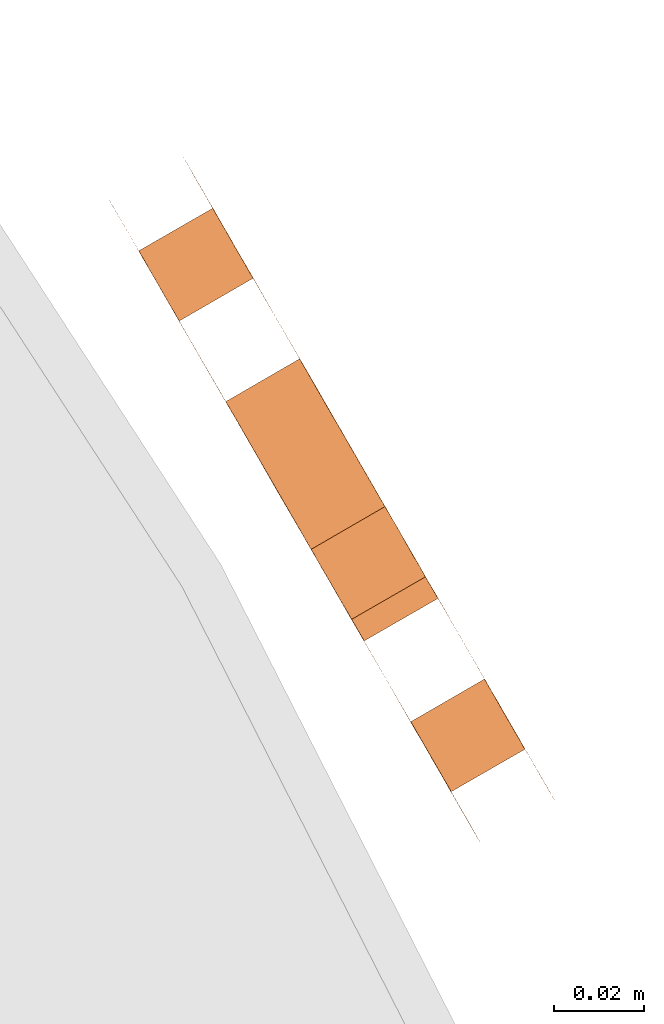
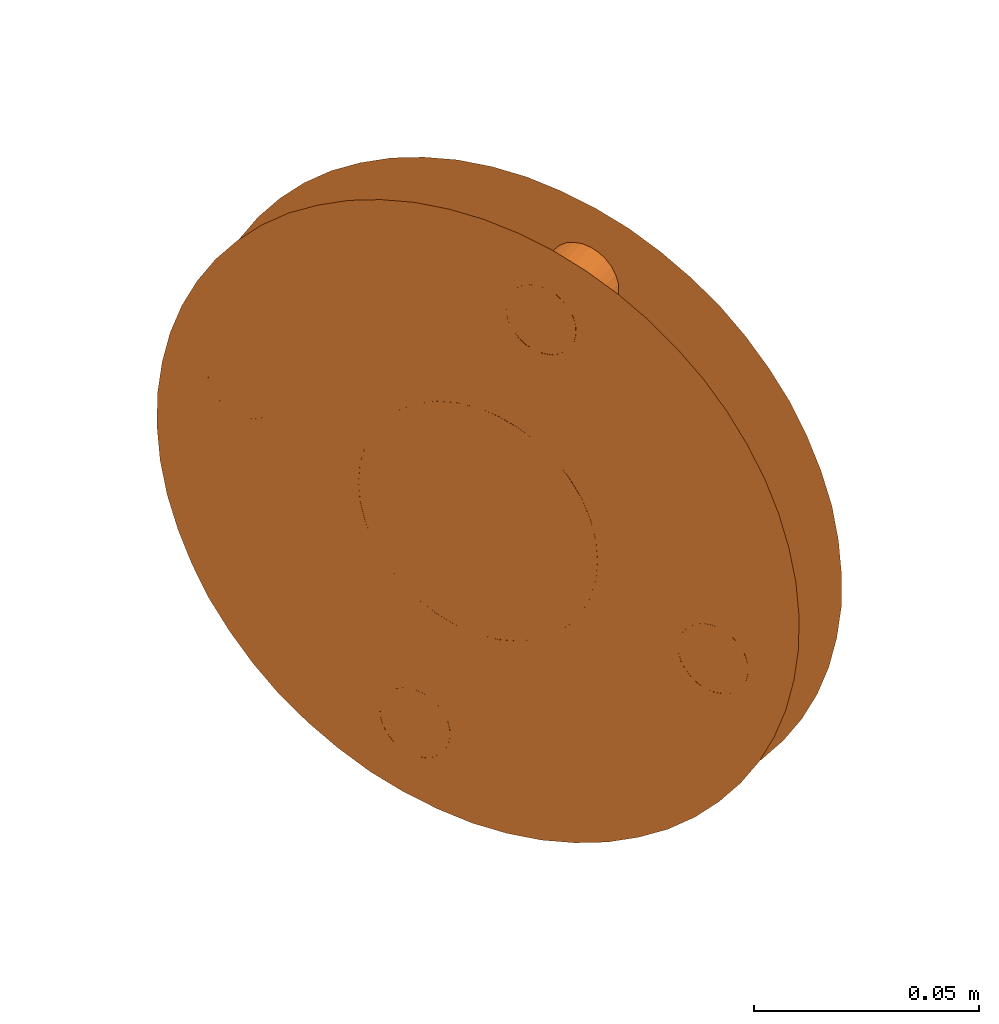
# One storey, part 91 of 126: 1 proxy.
"""IFC2X3 building model written with IfcOpenShell, lengths in millimetres."""

from ifc_helpers import new_model, si_unit, origin, origin_with_axes, place, context, project, spatial, faceted_brep, material, element, save


model = new_model("IFC2X3")

# Units and contexts
context_of_model_1 = context(None, 3, precision=0.1, world=origin())
context_of_model_2 = context(None, 3, precision=0.1, world=origin())
ifc_project = project(units=[si_unit("LENGTHUNIT", "METRE", prefix="MILLI"), si_unit("AREAUNIT", "SQUARE_METRE", prefix="CENTI"), si_unit("VOLUMEUNIT", "CUBIC_METRE", prefix="CENTI"), si_unit("MASSUNIT", "GRAM", prefix="KILO")], contexts=[context_of_model_1, context_of_model_2])

# Site, building, storey
site_placement = place(None, origin_with_axes())
site = spatial("IfcSite", under=ifc_project, at=site_placement, CompositionType="ELEMENT")
building_placement = place(site_placement, origin_with_axes())
building = spatial("IfcBuilding", under=site, at=building_placement, CompositionType="ELEMENT")
storey_placement = place(building_placement, origin_with_axes())
storey = spatial("IfcBuildingStorey", under=building, at=storey_placement, CompositionType="ELEMENT")

# Proxy
ifc_material = material(Name="STAHL")
proxy_placement = place(storey_placement, origin_with_axes())
element("IfcBuildingElementProxy", 1, at=proxy_placement, inside=storey, material=ifc_material, Name="profile", context=context_of_model_2, shape_type="Brep", body=[
    faceted_brep([(14977.9, 11935.6, 799.0), (14977.8, 11935.7, 790.0), (14977.2, 11936.7, 781.2), (14976.2, 11938.5, 772.5), (14974.7, 11941.1, 764.1), (14972.8, 11944.5, 756.0), (14970.4, 11948.6, 748.5), (14967.6, 11953.4, 741.5), (14964.5, 11958.8, 735.1), (14961.0, 11964.8, 729.4), (14957.3, 11971.3, 724.6), (14953.3, 11978.2, 720.5), (14949.1, 11985.4, 717.4), (14944.8, 11992.9, 715.1), (14940.4, 12000.6, 713.8), (14935.9, 12008.3, 713.5), (14931.5, 12016.0, 714.2), (14927.1, 12023.6, 715.8), (14922.8, 12031.0, 718.3), (14918.7, 12038.2, 721.8), (14914.8, 12044.9, 726.1), (14911.1, 12051.3, 731.2), (14907.8, 12057.1, 737.1), (14904.8, 12062.3, 743.7), (14902.1, 12066.9, 750.9), (14899.9, 12070.7, 758.7), (14898.1, 12073.8, 766.9), (14896.7, 12076.2, 775.4), (14895.8, 12077.7, 784.1), (14895.4, 12078.4, 793.0), (14895.5, 12078.3, 802.0), (14896.1, 12077.3, 810.8), (14897.1, 12075.5, 819.5), (14898.6, 12072.9, 827.9), (14913.6, 12085.0, 819.5), (14912.5, 12086.8, 810.8), (14912.0, 12087.8, 802.0), (14911.9, 12087.9, 793.0), (14912.3, 12087.2, 784.1), (14913.2, 12085.7, 775.4), (14914.5, 12083.3, 766.9), (14916.3, 12080.2, 758.7), (14918.6, 12076.4, 750.9), (14921.2, 12071.8, 743.7), (14924.2, 12066.6, 737.1), (14927.6, 12060.8, 731.2), (14931.2, 12054.4, 726.1), (14935.1, 12047.7, 721.8), (14939.2, 12040.5, 718.3), (14943.5, 12033.1, 715.8), (14947.9, 12025.5, 714.2), (14952.4, 12017.8, 713.5), (14956.8, 12010.1, 713.8), (14961.3, 12002.4, 715.1), (14965.6, 11994.9, 717.4), (14969.8, 11987.7, 720.5), (14973.7, 11980.8, 724.6), (14977.5, 11974.3, 729.4), (14980.9, 11968.3, 735.1), (14984.1, 11962.9, 741.5), (14986.8, 11958.1, 748.5), (14989.2, 11954.0, 756.0), (14991.2, 11950.6, 764.1), (14992.7, 11948.0, 772.5), (14993.7, 11946.2, 781.2), (14994.3, 11945.2, 790.0), (14994.3, 11945.1, 799.0), (14993.9, 11945.8, 807.9), (14993.1, 11947.3, 816.6), (14991.7, 11949.7, 825.1), (14989.9, 11952.8, 833.3), (14987.7, 11956.6, 841.1), (14985.0, 11961.2, 848.3), (14982.0, 11966.4, 854.9), (14978.7, 11972.2, 860.8), (14975.0, 11978.6, 865.9), (14971.1, 11985.3, 870.2), (14967.0, 11992.5, 873.7), (14962.7, 11999.9, 876.2), (14958.3, 12007.5, 877.8), (14953.9, 12015.2, 878.5), (14949.4, 12022.9, 878.2), (14945.0, 12030.6, 876.9), (14940.7, 12038.1, 874.6), (14936.5, 12045.3, 871.5), (14932.5, 12052.2, 867.4), (14928.8, 12058.7, 862.6), (14925.3, 12064.7, 856.9), (14922.2, 12070.1, 850.5), (14919.4, 12074.9, 843.5), (14917.0, 12079.0, 836.0), (14915.1, 12082.4, 827.9), (14900.6, 12069.5, 836.0), (14902.9, 12065.4, 843.5), (14905.7, 12060.6, 850.5), (14908.8, 12055.2, 856.9), (14912.3, 12049.2, 862.6), (14916.0, 12042.7, 867.4), (14920.0, 12035.8, 871.5), (14924.2, 12028.6, 874.6), (14928.5, 12021.1, 876.9), (14932.9, 12013.4, 878.2), (14937.4, 12005.7, 878.5), (14941.9, 11998.0, 877.8), (14946.3, 11990.4, 876.2), (14950.5, 11983.0, 873.7), (14954.7, 11975.8, 870.2), (14958.6, 11969.1, 865.9), (14962.2, 11962.7, 860.8), (14965.6, 11956.9, 854.9), (14968.6, 11951.7, 848.3), (14971.2, 11947.1, 841.1), (14973.5, 11943.3, 833.3), (14975.3, 11940.2, 825.1), (14976.6, 11937.8, 816.6), (14977.5, 11936.3, 807.9), (14960.8, 12003.2, 769.4), (14958.4, 12007.4, 767.1), (14941.9, 11997.9, 767.1), (14944.4, 11993.7, 769.4), (14955.8, 12011.9, 765.7), (14939.3, 12002.4, 765.7), (14953.1, 12016.5, 765.3), (14936.7, 12007.0, 765.3), (14950.5, 12021.1, 765.7), (14934.0, 12011.6, 765.7), (14947.9, 12025.6, 767.1), (14931.4, 12016.1, 767.1), (14945.4, 12029.8, 769.4), (14929.0, 12020.3, 769.4), (14943.2, 12033.6, 772.4), (14926.8, 12024.1, 772.4), (14941.3, 12036.9, 776.2), (14924.9, 12027.4, 776.2), (14939.8, 12039.6, 780.6), (14923.4, 12030.1, 780.6), (14938.7, 12041.5, 785.5), (14922.2, 12032.0, 785.5), (14938.0, 12042.7, 790.7), (14921.5, 12033.2, 790.7), (14937.7, 12043.1, 796.0), (14921.3, 12033.6, 796.0), (14938.0, 12042.7, 801.3), (14921.5, 12033.2, 801.3), (14938.7, 12041.5, 806.5), (14922.2, 12032.0, 806.5), (14939.8, 12039.6, 811.4), (14923.4, 12030.1, 811.4), (14941.3, 12036.9, 815.8), (14924.9, 12027.4, 815.8), (14943.2, 12033.6, 819.6), (14926.8, 12024.1, 819.6), (14945.4, 12029.8, 822.6), (14929.0, 12020.3, 822.6), (14984.6, 11962.0, 771.2), (14968.1, 11952.5, 771.2), (14969.1, 11950.8, 772.0), (14985.6, 11960.3, 772.0), (14983.5, 11963.9, 770.8), (14967.0, 11954.4, 770.8), (14982.4, 11965.8, 771.0), (14966.0, 11956.3, 771.0), (14981.4, 11967.6, 771.7), (14964.9, 11958.1, 771.7), (14980.5, 11969.1, 772.9), (14964.0, 11959.6, 772.9), (14979.7, 11970.4, 774.4), (14963.3, 11960.9, 774.4), (14979.2, 11971.4, 776.3), (14962.7, 11961.9, 776.3), (14978.9, 11971.9, 778.4), (14962.4, 11962.4, 778.4), (14978.8, 11972.0, 780.5), (14962.4, 11962.5, 780.5), (14979.0, 11971.6, 782.7), (14962.6, 11962.1, 782.7), (14979.5, 11970.8, 784.6), (14963.0, 11961.3, 784.6), (14980.2, 11969.6, 786.3), (14963.7, 11960.1, 786.3), (14981.1, 11968.1, 787.6), (14964.6, 11958.6, 787.6), (14924.2, 12066.6, 803.5), (14907.7, 12057.1, 803.5), (14908.7, 12055.4, 804.4), (14925.2, 12064.9, 804.4), (14923.1, 12068.5, 803.2), (14906.7, 12059.0, 803.2), (14922.0, 12070.3, 803.4), (14905.6, 12060.8, 803.4), (14921.0, 12072.1, 804.0), (14904.6, 12062.6, 804.0), (14920.1, 12073.7, 805.2), (14903.6, 12064.2, 805.2), (14919.3, 12075.0, 806.8), (14902.9, 12065.5, 806.8), (14918.8, 12076.0, 808.6), (14902.3, 12066.5, 808.6), (14918.5, 12076.5, 810.7), (14902.0, 12067.0, 810.7), (14918.5, 12076.6, 812.9), (14902.0, 12067.1, 812.9), (14918.7, 12076.2, 815.0), (14902.2, 12066.7, 815.0), (14919.1, 12075.4, 817.0), (14902.7, 12065.9, 817.0), (14919.8, 12074.2, 818.7), (14903.4, 12064.7, 818.7), (14920.7, 12072.7, 820.0), (14904.2, 12063.2, 820.0), (14946.3, 12028.3, 727.0), (14929.8, 12018.8, 727.0), (14930.8, 12017.1, 727.8), (14947.3, 12026.6, 727.8), (14945.2, 12030.2, 726.6), (14928.8, 12020.7, 726.6), (14944.1, 12032.1, 726.8), (14927.7, 12022.6, 726.8), (14943.1, 12033.9, 727.5), (14926.7, 12024.4, 727.5), (14942.2, 12035.4, 728.7), (14925.7, 12025.9, 728.7), (14941.4, 12036.7, 730.2), (14925.0, 12027.2, 730.2), (14940.9, 12037.7, 732.1), (14924.4, 12028.2, 732.1), (14940.6, 12038.2, 734.2), (14924.1, 12028.7, 734.2), (14940.5, 12038.3, 736.4), (14924.1, 12028.8, 736.4), (14940.8, 12037.9, 738.5), (14924.3, 12028.4, 738.5), (14941.2, 12037.1, 740.4), (14924.8, 12027.6, 740.4), (14941.9, 12035.9, 742.1), (14925.5, 12026.4, 742.1), (14942.8, 12034.4, 743.4), (14926.3, 12024.9, 743.4), (14962.5, 12000.3, 847.7), (14946.0, 11990.8, 847.7), (14947.0, 11989.1, 848.6), (14963.5, 11998.6, 848.6), (14961.4, 12002.2, 847.4), (14944.9, 11992.7, 847.4), (14960.3, 12004.1, 847.6), (14943.9, 11994.6, 847.6), (14959.3, 12005.8, 848.2), (14942.8, 11996.3, 848.2), (14958.4, 12007.4, 849.4), (14941.9, 11997.9, 849.4), (14957.6, 12008.7, 851.0), (14941.2, 11999.2, 851.0), (14957.1, 12009.7, 852.8), (14940.6, 12000.2, 852.8), (14956.8, 12010.2, 854.9), (14940.3, 12000.7, 854.9), (14956.7, 12010.3, 857.1), (14940.3, 12000.8, 857.1), (14956.9, 12009.9, 859.2), (14940.5, 12000.4, 859.2), (14957.4, 12009.1, 861.2), (14941.0, 11999.6, 861.2), (14958.1, 12007.9, 862.9), (14941.6, 11998.4, 862.9), (14959.0, 12006.4, 864.2), (14942.5, 11996.9, 864.2), (14960.0, 12004.7, 865.0), (14943.5, 11995.2, 865.0), (14961.0, 12002.8, 865.4), (14944.6, 11993.3, 865.4), (14962.1, 12000.9, 865.2), (14945.7, 11991.4, 865.2), (14963.1, 11999.1, 864.5), (14946.7, 11989.6, 864.5), (14964.1, 11997.6, 863.3), (14947.6, 11988.1, 863.3), (14964.8, 11996.3, 861.8), (14948.4, 11986.8, 861.8), (14965.3, 11995.3, 859.9), (14948.9, 11985.8, 859.9), (14965.7, 11994.8, 857.8), (14949.2, 11985.3, 857.8), (14965.7, 11994.7, 855.6), (14949.2, 11985.2, 855.6), (14965.5, 11995.1, 853.5), (14949.0, 11985.6, 853.5), (14965.0, 11995.9, 851.6), (14948.6, 11986.4, 851.6), (14964.3, 11997.1, 849.9), (14947.9, 11987.6, 849.9), (14943.8, 12032.7, 744.3), (14927.3, 12023.2, 744.3), (14944.9, 12030.8, 744.6), (14928.4, 12021.3, 744.6), (14945.9, 12028.9, 744.4), (14929.5, 12019.4, 744.4), (14947.0, 12027.2, 743.8), (14930.5, 12017.7, 743.8), (14947.9, 12025.6, 742.6), (14931.4, 12016.1, 742.6), (14948.6, 12024.3, 741.0), (14932.2, 12014.8, 741.0), (14949.2, 12023.3, 739.2), (14932.7, 12013.8, 739.2), (14949.5, 12022.8, 737.1), (14933.0, 12013.3, 737.1), (14949.5, 12022.7, 734.9), (14933.1, 12013.2, 734.9), (14949.3, 12023.1, 732.8), (14932.8, 12013.6, 732.8), (14948.8, 12023.9, 730.8), (14932.4, 12014.4, 730.8), (14948.2, 12025.1, 729.1), (14931.7, 12015.6, 729.1), (14921.7, 12071.0, 820.8), (14905.2, 12061.5, 820.8), (14922.8, 12069.1, 821.2), (14906.3, 12059.6, 821.2), (14923.8, 12067.2, 821.0), (14907.4, 12057.7, 821.0), (14924.9, 12065.4, 820.3), (14908.4, 12055.9, 820.3), (14925.8, 12063.9, 819.1), (14909.3, 12054.4, 819.1), (14926.5, 12062.6, 817.6), (14910.1, 12053.1, 817.6), (14927.1, 12061.6, 815.7), (14910.6, 12052.1, 815.7), (14927.4, 12061.1, 813.6), (14910.9, 12051.6, 813.6), (14927.4, 12061.0, 811.5), (14911.0, 12051.5, 811.5), (14927.2, 12061.4, 809.3), (14910.8, 12051.9, 809.3), (14926.7, 12062.2, 807.4), (14910.3, 12052.7, 807.4), (14926.1, 12063.4, 805.7), (14909.6, 12053.9, 805.7), (14982.1, 11966.4, 788.5), (14965.6, 11956.9, 788.5), (14983.1, 11964.5, 788.8), (14966.7, 11955.0, 788.8), (14984.2, 11962.7, 788.6), (14967.8, 11953.2, 788.6), (14985.2, 11960.9, 788.0), (14968.8, 11951.4, 788.0), (14986.2, 11959.3, 786.8), (14969.7, 11949.8, 786.8), (14986.9, 11958.0, 785.2), (14970.5, 11948.5, 785.2), (14987.4, 11957.0, 783.4), (14971.0, 11947.5, 783.4), (14987.7, 11956.5, 781.3), (14971.3, 11947.0, 781.3), (14987.8, 11956.4, 779.1), (14971.3, 11946.9, 779.1), (14987.6, 11956.8, 777.0), (14971.1, 11947.3, 777.0), (14987.1, 11957.6, 775.0), (14970.7, 11948.1, 775.0), (14986.4, 11958.8, 773.3), (14970.0, 11949.3, 773.3), (14963.0, 11999.4, 772.4), (14964.9, 11996.1, 776.2), (14966.4, 11993.4, 780.6), (14967.6, 11991.5, 785.5), (14968.3, 11990.3, 790.7), (14968.5, 11989.9, 796.0), (14968.3, 11990.3, 801.3), (14967.6, 11991.5, 806.5), (14966.4, 11993.4, 811.4), (14964.9, 11996.1, 815.8), (14963.0, 11999.4, 819.6), (14960.8, 12003.2, 822.6), (14958.4, 12007.4, 824.9), (14955.8, 12011.9, 826.3), (14953.1, 12016.5, 826.8), (14950.5, 12021.1, 826.3), (14947.9, 12025.6, 824.9), (14931.4, 12016.1, 824.9), (14934.0, 12011.6, 826.3), (14936.7, 12007.0, 826.8), (14939.3, 12002.4, 826.3), (14941.9, 11997.9, 824.9), (14944.4, 11993.7, 822.6), (14946.6, 11989.9, 819.6), (14948.4, 11986.6, 815.8), (14950.0, 11983.9, 811.4), (14951.1, 11982.0, 806.5), (14951.8, 11980.8, 801.3), (14952.0, 11980.4, 796.0), (14951.8, 11980.8, 790.7), (14951.1, 11982.0, 785.5), (14950.0, 11983.9, 780.6), (14948.4, 11986.6, 776.2), (14946.6, 11989.9, 772.4)], [[[0, 1, 2, 3, 4, 5, 6, 7, 8, 9, 10, 11, 12, 13, 14, 15, 16, 17, 18, 19, 20, 21, 22, 23, 24, 25, 26, 27, 28, 29, 30, 31, 32, 33, 34, 35, 36, 37, 38, 39, 40, 41, 42, 43, 44, 45, 46, 47, 48, 49, 50, 51, 52, 53, 54, 55, 56, 57, 58, 59, 60, 61, 62, 63, 64, 65, 66, 67, 68, 69, 70, 71, 72, 73, 74, 75, 76, 77, 78, 79, 80, 81, 82, 83, 84, 85, 86, 87, 88, 89, 90, 91, 34, 33, 92, 93, 94, 95, 96, 97, 98, 99, 100, 101, 102, 103, 104, 105, 106, 107, 108, 109, 110, 111, 112, 113, 114, 115]], [[116, 117, 118, 119]], [[117, 120, 121, 118]], [[120, 122, 123, 121]], [[122, 124, 125, 123]], [[124, 126, 127, 125]], [[126, 128, 129, 127]], [[128, 130, 131, 129]], [[130, 132, 133, 131]], [[132, 134, 135, 133]], [[134, 136, 137, 135]], [[136, 138, 139, 137]], [[138, 140, 141, 139]], [[140, 142, 143, 141]], [[142, 144, 145, 143]], [[144, 146, 147, 145]], [[146, 148, 149, 147]], [[148, 150, 151, 149]], [[152, 153, 151, 150]], [[154, 155, 156, 157]], [[158, 159, 155, 154]], [[160, 161, 159, 158]], [[162, 163, 161, 160]], [[164, 165, 163, 162]], [[166, 167, 165, 164]], [[168, 169, 167, 166]], [[170, 171, 169, 168]], [[172, 173, 171, 170]], [[174, 175, 173, 172]], [[176, 177, 175, 174]], [[178, 179, 177, 176]], [[180, 181, 179, 178]], [[182, 183, 184, 185]], [[186, 187, 183, 182]], [[188, 189, 187, 186]], [[190, 191, 189, 188]], [[192, 193, 191, 190]], [[194, 195, 193, 192]], [[196, 197, 195, 194]], [[198, 199, 197, 196]], [[200, 201, 199, 198]], [[202, 203, 201, 200]], [[204, 205, 203, 202]], [[206, 207, 205, 204]], [[208, 209, 207, 206]], [[210, 211, 212, 213]], [[214, 215, 211, 210]], [[216, 217, 215, 214]], [[218, 219, 217, 216]], [[220, 221, 219, 218]], [[222, 223, 221, 220]], [[224, 225, 223, 222]], [[226, 227, 225, 224]], [[228, 229, 227, 226]], [[230, 231, 229, 228]], [[232, 233, 231, 230]], [[234, 235, 233, 232]], [[234, 236, 237, 235]], [[238, 239, 240, 241]], [[242, 243, 239, 238]], [[244, 245, 243, 242]], [[246, 247, 245, 244]], [[248, 249, 247, 246]], [[250, 251, 249, 248]], [[252, 253, 251, 250]], [[254, 255, 253, 252]], [[256, 257, 255, 254]], [[258, 259, 257, 256]], [[260, 261, 259, 258]], [[262, 263, 261, 260]], [[264, 265, 263, 262]], [[264, 266, 267, 265]], [[266, 268, 269, 267]], [[268, 270, 271, 269]], [[270, 272, 273, 271]], [[272, 274, 275, 273]], [[274, 276, 277, 275]], [[276, 278, 279, 277]], [[278, 280, 281, 279]], [[280, 282, 283, 281]], [[282, 284, 285, 283]], [[284, 286, 287, 285]], [[286, 288, 289, 287]], [[288, 241, 240, 289]], [[290, 291, 237, 236]], [[292, 293, 291, 290]], [[294, 295, 293, 292]], [[296, 297, 295, 294]], [[298, 299, 297, 296]], [[300, 301, 299, 298]], [[302, 303, 301, 300]], [[304, 305, 303, 302]], [[306, 307, 305, 304]], [[308, 309, 307, 306]], [[310, 311, 309, 308]], [[312, 313, 311, 310]], [[213, 212, 313, 312]], [[314, 315, 209, 208]], [[316, 317, 315, 314]], [[318, 319, 317, 316]], [[320, 321, 319, 318]], [[322, 323, 321, 320]], [[324, 325, 323, 322]], [[326, 327, 325, 324]], [[328, 329, 327, 326]], [[330, 331, 329, 328]], [[332, 333, 331, 330]], [[334, 335, 333, 332]], [[336, 337, 335, 334]], [[185, 184, 337, 336]], [[180, 338, 339, 181]], [[338, 340, 341, 339]], [[340, 342, 343, 341]], [[342, 344, 345, 343]], [[344, 346, 347, 345]], [[346, 348, 349, 347]], [[348, 350, 351, 349]], [[350, 352, 353, 351]], [[352, 354, 355, 353]], [[354, 356, 357, 355]], [[356, 358, 359, 357]], [[358, 360, 361, 359]], [[360, 157, 156, 361]], [[66, 65, 64, 63, 62, 61, 60, 160, 158, 154, 157, 360, 358, 356, 354, 352, 350, 348, 346, 344, 342, 340, 338, 180, 178, 176, 174, 172, 170, 168, 166, 164, 362, 363, 364, 365, 366, 367, 368, 369, 370, 371, 372, 373, 374, 375, 376, 377, 378, 254, 252, 250, 248, 246, 244, 242, 238, 241, 288, 286, 284, 282, 280, 278, 276, 274, 272, 270, 268, 266, 264, 262, 260, 258, 256, 254, 378, 152, 150, 148, 146, 144, 142, 140, 138, 136, 182, 185, 336, 334, 332, 330, 328, 326, 324, 322, 320, 318, 316, 314, 208, 206, 204, 202, 200, 198, 196, 194, 192, 190, 188, 186, 182, 136, 134, 132, 130, 128, 126, 124, 122, 120, 117, 304, 302, 300, 298, 296, 294, 292, 290, 236, 234, 232, 230, 228, 226, 224, 222, 220, 218, 216, 214, 210, 213, 312, 310, 308, 306, 304, 117, 116, 362, 164, 162, 160, 60, 59, 58, 57, 56, 55, 54, 53, 52, 51, 50, 49, 48, 47, 46, 45, 44, 43, 42, 41, 40, 39, 38, 37, 36, 35, 34, 91, 90, 89, 88, 87, 86, 85, 84, 83, 82, 81, 80, 79, 78, 77, 76, 75, 74, 73, 72, 71, 70, 69, 68, 67]], [[0, 115, 114, 113, 112, 111, 110, 109, 108, 107, 106, 105, 104, 103, 102, 101, 100, 99, 98, 97, 96, 95, 94, 93, 92, 33, 32, 31, 30, 193, 195, 197, 199, 201, 203, 205, 207, 209, 315, 317, 319, 321, 323, 325, 327, 329, 331, 333, 335, 337, 184, 183, 137, 139, 141, 143, 145, 147, 149, 151, 153, 379, 380, 381, 382, 383, 384, 385, 386, 289, 240, 239, 243, 245, 247, 249, 251, 253, 255, 257, 259, 261, 263, 265, 267, 269, 271, 273, 275, 277, 279, 281, 283, 285, 287, 289, 386, 387, 388, 389, 390, 391, 392, 393, 394, 395, 165, 167, 169, 171, 173, 175, 177, 179, 181, 339, 341, 343, 345, 347, 349, 351, 353, 355, 357, 359, 361, 156, 155, 159, 161, 163, 165, 395, 119, 118, 121, 123, 125, 127, 129, 131, 133, 235, 237, 291, 293, 295, 297, 299, 301, 303, 305, 307, 309, 311, 313, 212, 211, 215, 217, 219, 221, 223, 225, 227, 229, 231, 233, 235, 133, 135, 137, 183, 187, 189, 191, 193, 30, 29, 28, 27, 26, 25, 24, 23, 22, 21, 20, 19, 18, 17, 16, 15, 14, 13, 12, 11, 10, 9, 8, 7, 6, 5, 4, 3, 2, 1]], [[152, 378, 379, 153]], [[378, 377, 380, 379]], [[377, 376, 381, 380]], [[376, 375, 382, 381]], [[375, 374, 383, 382]], [[374, 373, 384, 383]], [[373, 372, 385, 384]], [[372, 371, 386, 385]], [[371, 370, 387, 386]], [[370, 369, 388, 387]], [[369, 368, 389, 388]], [[368, 367, 390, 389]], [[367, 366, 391, 390]], [[366, 365, 392, 391]], [[365, 364, 393, 392]], [[364, 363, 394, 393]], [[363, 362, 395, 394]], [[362, 116, 119, 395]]]),
])

save(model, "model.ifc")
